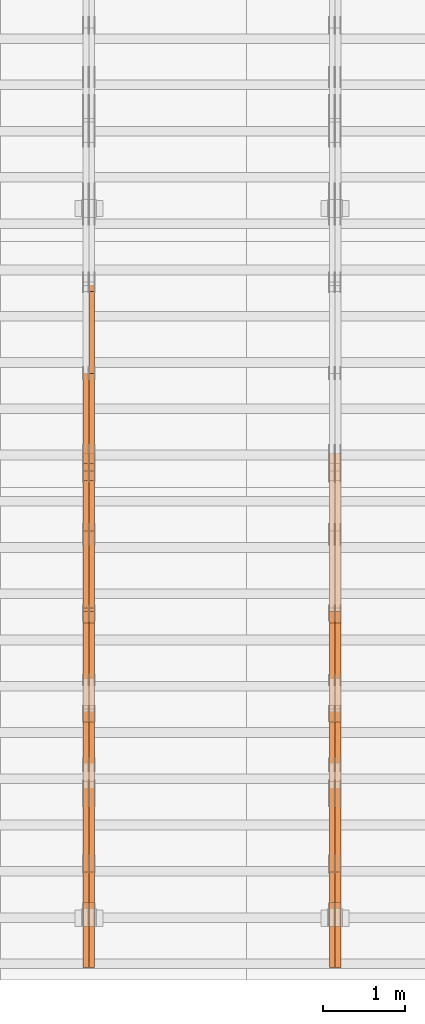
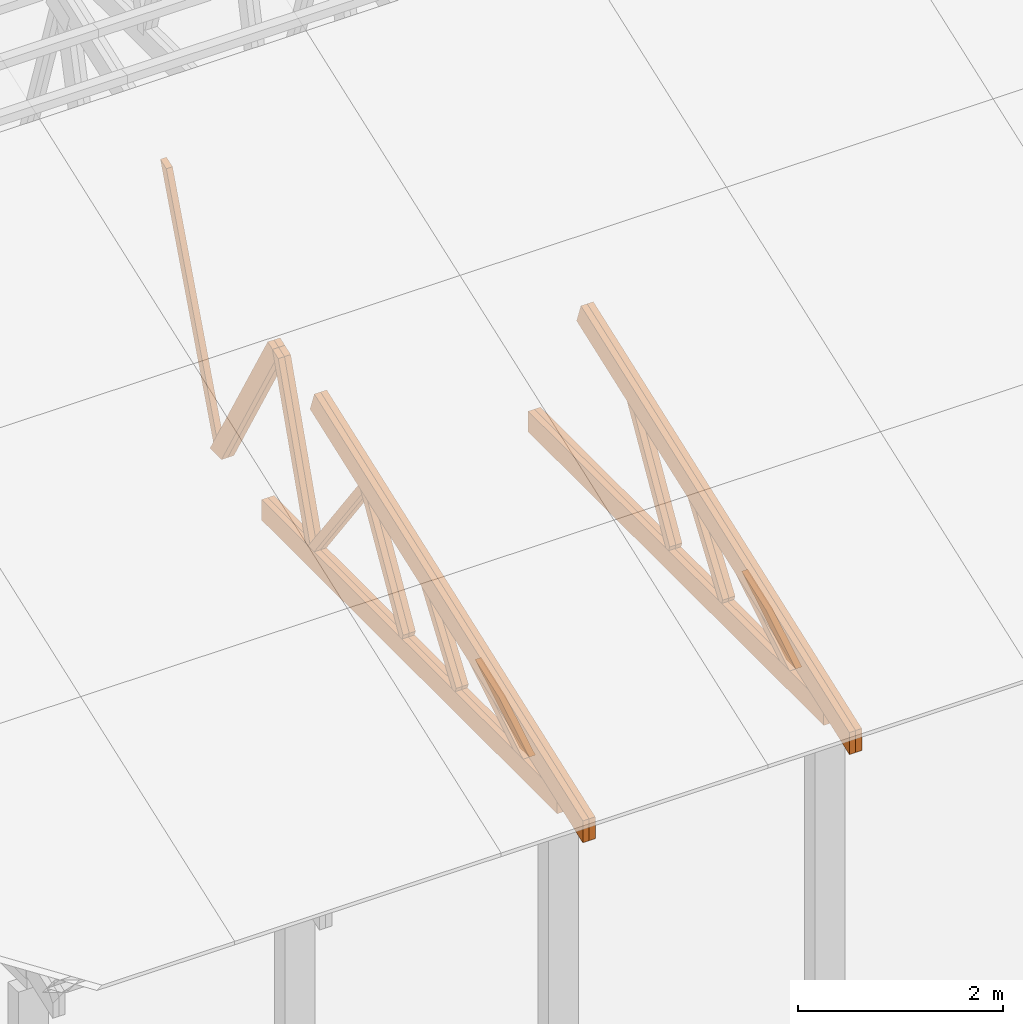
# One storey, part 14 of 189: 27 proxies.
"""IFC2X3 building model written with IfcOpenShell, lengths in millimetres."""

from ifc_helpers import new_model, entity, si_unit, converted_unit, derived_unit, direction, frame, origin, place, context, subcontext, project, spatial, polyline, outline, extrude, source, transform, mapped, material, type_object, type_shapes, element, save


model = new_model("IFC2X3")

# Units and contexts
model_context = context("Model", 3, precision=0.01, world=origin(), true_north=direction((6.12303176911189e-17, 1.0)))
body_context = subcontext(model_context, "Body", "Model", "MODEL_VIEW")
ifc_project = project(units=[si_unit("LENGTHUNIT", "METRE", prefix="MILLI"), si_unit("AREAUNIT", "SQUARE_METRE"), si_unit("VOLUMEUNIT", "CUBIC_METRE"), converted_unit("PLANEANGLEUNIT", "DEGREE", entity("IfcRatioMeasure", 0.0174532925199433), si_unit("PLANEANGLEUNIT", "RADIAN"), dimensions=[0, 0, 0, 0, 0, 0, 0]), si_unit("MASSUNIT", "GRAM", prefix="KILO"), derived_unit("MASSDENSITYUNIT", [(si_unit("MASSUNIT", "GRAM", prefix="KILO"), 1), (si_unit("LENGTHUNIT", "METRE"), -3)]), si_unit("TIMEUNIT", "SECOND"), si_unit("FREQUENCYUNIT", "HERTZ"), si_unit("THERMODYNAMICTEMPERATUREUNIT", "DEGREE_CELSIUS"), derived_unit("THERMALTRANSMITTANCEUNIT", [(si_unit("MASSUNIT", "GRAM", prefix="KILO"), 1), (si_unit("THERMODYNAMICTEMPERATUREUNIT", "KELVIN"), -1), (si_unit("TIMEUNIT", "SECOND"), -3)]), derived_unit("VOLUMETRICFLOWRATEUNIT", [(si_unit("LENGTHUNIT", "METRE"), 3), (si_unit("TIMEUNIT", "SECOND"), -1)]), si_unit("ELECTRICCURRENTUNIT", "AMPERE"), si_unit("ELECTRICVOLTAGEUNIT", "VOLT"), si_unit("POWERUNIT", "WATT"), si_unit("FORCEUNIT", "NEWTON"), si_unit("ILLUMINANCEUNIT", "LUX"), si_unit("LUMINOUSFLUXUNIT", "LUMEN"), si_unit("LUMINOUSINTENSITYUNIT", "CANDELA"), derived_unit("USERDEFINED", [(si_unit("MASSUNIT", "GRAM", prefix="KILO"), -1), (si_unit("LENGTHUNIT", "METRE"), -2), (si_unit("TIMEUNIT", "SECOND"), 3), (si_unit("LUMINOUSFLUXUNIT", "LUMEN"), 1)]), derived_unit("LINEARVELOCITYUNIT", [(si_unit("LENGTHUNIT", "METRE"), 1), (si_unit("TIMEUNIT", "SECOND"), -1)]), si_unit("PRESSUREUNIT", "PASCAL"), derived_unit("USERDEFINED", [(si_unit("LENGTHUNIT", "METRE"), -2), (si_unit("MASSUNIT", "GRAM", prefix="KILO"), 1), (si_unit("TIMEUNIT", "SECOND"), -2)])], contexts=[model_context])

# Site, building, storey
site_placement = place(None, origin())
site = spatial("IfcSite", under=ifc_project, at=site_placement, CompositionType="ELEMENT")
building_placement = place(site_placement, origin())
building = spatial("IfcBuilding", under=site, at=building_placement, CompositionType="ELEMENT")
storey_placement = place(building_placement, origin())
storey = spatial("IfcBuildingStorey", under=building, at=storey_placement, Name="Default", CompositionType="ELEMENT", Elevation=0.0)

# Proxies
ifc_material_1 = material(Name="IfcSurfaceStyle #65994")
building_element_proxy_type_1 = type_object("IfcBuildingElementProxyType", Name="T1-W11 65992", PredefinedType="NOTDEFINED", material=ifc_material_1)
shared_shape_1 = source(origin(), body_context, "Body", "SweptSolid", [
    extrude(outline(polyline([(593.358012843793, -552.565239103314), (742.388662259985, -552.565239103314), (-410.498749190676, 401.275038694583), (-462.246133468927, 382.44069706518), (-463.001792444175, 321.414742446865), (593.358012843793, -552.565239103314)])), frame((599.94412413079, 47.5003788877286, 0.0), z_axis=(0.0, 0.0, 1.0), x_axis=(0.770483455324544, 0.637459994879013, 0.0)), (0.0, 0.0, 1.0), 69.9999999999999),
])
type_shapes(building_element_proxy_type_1, [shared_shape_1])
proxy_1_placement = place(building_placement, frame((12300.0, 2983.26655629375, 269.034992751429), z_axis=(-1.0, 0.0, 0.0), x_axis=(0.0, 0.505995901100606, 0.862535882192379)))
element("IfcBuildingElementProxy", 1, at=proxy_1_placement, inside=storey, type_object=building_element_proxy_type_1, material=ifc_material_1, Name="T1-W11", context=body_context, shape_type="MappedRepresentation", body=[
    mapped(shared_shape_1, transform((0.0, 0.0, 0.0), scale=1.0)),
])
ifc_material_2 = material(Name="IfcSurfaceStyle #65928")
building_element_proxy_type_2 = type_object("IfcBuildingElementProxyType", Name="T1-W11 65926", PredefinedType="NOTDEFINED", material=ifc_material_2)
shared_shape_2 = source(origin(), body_context, "Body", "SweptSolid", [
    extrude(outline(polyline([(593.358012843793, -552.565239103314), (742.388662259985, -552.565239103314), (-410.498749190676, 401.275038694583), (-462.246133468927, 382.44069706518), (-463.001792444175, 321.414742446865), (593.358012843793, -552.565239103314)])), frame((599.94412413079, 47.5003788877286, 0.0), z_axis=(0.0, 0.0, 1.0), x_axis=(0.770483455324544, 0.637459994879013, 0.0)), (0.0, 0.0, 1.0), 69.9999999999999),
])
type_shapes(building_element_proxy_type_2, [shared_shape_2])
proxy_2_placement = place(building_placement, frame((12230.0, 2983.26655629375, 269.034992751429), z_axis=(-1.0, 0.0, 0.0), x_axis=(0.0, 0.505995901100606, 0.862535882192379)))
element("IfcBuildingElementProxy", 2, at=proxy_2_placement, inside=storey, type_object=building_element_proxy_type_2, material=ifc_material_2, Name="T1-W11", context=body_context, shape_type="MappedRepresentation", body=[
    mapped(shared_shape_2, transform((0.0, 0.0, 0.0), scale=1.0)),
])
ifc_material_3 = material(Name="IfcSurfaceStyle #65466")
building_element_proxy_type_3 = type_object("IfcBuildingElementProxyType", Name="T1-W13 65464", PredefinedType="NOTDEFINED", material=ifc_material_3)
shared_shape_3 = source(origin(), body_context, "Body", "SweptSolid", [
    extrude(outline(polyline([(404.740440720218, -341.48092914206), (570.336320797765, -341.48092914206), (-287.911826743206, 259.650691447848), (-342.395697357435, 239.820346030744), (-344.769237417342, 183.490820805529), (404.740440720218, -341.48092914206)])), frame((418.029573061951, 47.5005675782689, 0.0), z_axis=(0.0, 0.0, 1.0), x_axis=(0.819070847746389, 0.573692379565924, 0.0)), (0.0, 0.0, 1.0), 69.9999999999999),
])
type_shapes(building_element_proxy_type_3, [shared_shape_3])
proxy_3_placement = place(building_placement, frame((12300.0, 1951.16403402681, 272.239720286334), z_axis=(-1.0, 0.0, 0.0), x_axis=(0.0, 0.573462629043499, 0.819231721242848)))
element("IfcBuildingElementProxy", 3, at=proxy_3_placement, inside=storey, type_object=building_element_proxy_type_3, material=ifc_material_3, Name="T1-W13", context=body_context, shape_type="MappedRepresentation", body=[
    mapped(shared_shape_3, transform((0.0, 0.0, 0.0), scale=1.0)),
])
ifc_material_4 = material(Name="IfcSurfaceStyle #65400")
building_element_proxy_type_4 = type_object("IfcBuildingElementProxyType", Name="T1-W13 65398", PredefinedType="NOTDEFINED", material=ifc_material_4)
shared_shape_4 = source(origin(), body_context, "Body", "SweptSolid", [
    extrude(outline(polyline([(404.740440720218, -341.48092914206), (570.336320797765, -341.48092914206), (-287.911826743206, 259.650691447848), (-342.395697357435, 239.820346030744), (-344.769237417342, 183.490820805529), (404.740440720218, -341.48092914206)])), frame((418.029573061951, 47.5005675782689, 0.0), z_axis=(0.0, 0.0, 1.0), x_axis=(0.819070847746389, 0.573692379565924, 0.0)), (0.0, 0.0, 1.0), 69.9999999999999),
])
type_shapes(building_element_proxy_type_4, [shared_shape_4])
proxy_4_placement = place(building_placement, frame((12230.0, 1951.16403402681, 272.239720286334), z_axis=(-1.0, 0.0, 0.0), x_axis=(0.0, 0.573462629043499, 0.819231721242848)))
element("IfcBuildingElementProxy", 4, at=proxy_4_placement, inside=storey, type_object=building_element_proxy_type_4, material=ifc_material_4, Name="T1-W13", context=body_context, shape_type="MappedRepresentation", body=[
    mapped(shared_shape_4, transform((0.0, 0.0, 0.0), scale=1.0)),
])
ifc_material_5 = material(Name="IfcSurfaceStyle #64938")
building_element_proxy_type_5 = type_object("IfcBuildingElementProxyType", Name="T1-W12 64936", PredefinedType="NOTDEFINED", material=ifc_material_5)
shared_shape_5 = source(origin(), body_context, "Body", "SweptSolid", [
    extrude(outline(polyline([(-671.888430889784, -47.499785620702), (344.892972119224, -47.499785620702), (503.856463083211, 47.4997856207019), (-176.861004312651, 47.499785620702), (-671.888430889784, -47.499785620702)])), frame((503.857114243549, 47.5002636410509, 0.0), z_axis=(0.0, 0.0, 1.0), x_axis=(-1.0, 0.0, 0.0)), (0.0, 0.0, 1.0), 69.9999999999999),
])
type_shapes(building_element_proxy_type_5, [shared_shape_5])
proxy_5_placement = place(building_placement, frame((12300.0, 665.58122707747, 245.000076287477), z_axis=(-1.0, 0.0, 0.0), x_axis=(0.0, 0.858392121304013, 0.51299411895576)))
element("IfcBuildingElementProxy", 5, at=proxy_5_placement, inside=storey, type_object=building_element_proxy_type_5, material=ifc_material_5, Name="T1-W12", context=body_context, shape_type="MappedRepresentation", body=[
    mapped(shared_shape_5, transform((0.0, 0.0, 0.0), scale=1.0)),
])
ifc_material_6 = material(Name="IfcSurfaceStyle #64881")
building_element_proxy_type_6 = type_object("IfcBuildingElementProxyType", Name="T1-W12 64879", PredefinedType="NOTDEFINED", material=ifc_material_6)
shared_shape_6 = source(origin(), body_context, "Body", "SweptSolid", [
    extrude(outline(polyline([(-671.888430889784, -47.499785620702), (344.892972119224, -47.499785620702), (503.856463083211, 47.4997856207019), (-176.861004312651, 47.499785620702), (-671.888430889784, -47.499785620702)])), frame((503.857114243549, 47.5002636410509, 0.0), z_axis=(0.0, 0.0, 1.0), x_axis=(-1.0, 0.0, 0.0)), (0.0, 0.0, 1.0), 69.9999999999999),
])
type_shapes(building_element_proxy_type_6, [shared_shape_6])
proxy_6_placement = place(building_placement, frame((12230.0, 665.58122707747, 245.000076287477), z_axis=(-1.0, 0.0, 0.0), x_axis=(0.0, 0.858392121304013, 0.51299411895576)))
element("IfcBuildingElementProxy", 6, at=proxy_6_placement, inside=storey, type_object=building_element_proxy_type_6, material=ifc_material_6, Name="T1-W12", context=body_context, shape_type="MappedRepresentation", body=[
    mapped(shared_shape_6, transform((0.0, 0.0, 0.0), scale=1.0)),
])
ifc_material_7 = material(Name="IfcSurfaceStyle #64122")
building_element_proxy_type_7 = type_object("IfcBuildingElementProxyType", Name="T1-B2 64120", PredefinedType="NOTDEFINED", material=ifc_material_7)
shared_shape_7 = source(origin(), body_context, "Body", "SweptSolid", [
    extrude(outline(polyline([(-3399.385546875, -125.855288696291), (2363.08125, -125.855288696291), (2363.08125, 13.4211547851572), (2072.60859375, 119.144711303712), (-3399.385546875, 119.144711303712), (-3399.385546875, -125.855288696291)])), frame((2363.08125, 119.144711303712, 0.0), z_axis=(0.0, 0.0, 1.0), x_axis=(-1.0, 0.0, 0.0)), (0.0, 0.0, 1.0), 69.9999999999997),
])
type_shapes(building_element_proxy_type_7, [shared_shape_7])
proxy_7_placement = place(building_placement, frame((12300.0, 0.0, 245.0), z_axis=(-1.0, 0.0, 0.0), x_axis=(0.0, 1.0, 0.0)))
element("IfcBuildingElementProxy", 7, at=proxy_7_placement, inside=storey, type_object=building_element_proxy_type_7, material=ifc_material_7, Name="T1-B2", context=body_context, shape_type="MappedRepresentation", body=[
    mapped(shared_shape_7, transform((0.0, 0.0, 0.0), scale=1.0)),
])
ifc_material_8 = material(Name="IfcSurfaceStyle #64056")
building_element_proxy_type_8 = type_object("IfcBuildingElementProxyType", Name="T1-B2 64054", PredefinedType="NOTDEFINED", material=ifc_material_8)
shared_shape_8 = source(origin(), body_context, "Body", "SweptSolid", [
    extrude(outline(polyline([(-3399.385546875, -125.855288696291), (2363.08125, -125.855288696291), (2363.08125, 13.4211547851572), (2072.60859375, 119.144711303712), (-3399.385546875, 119.144711303712), (-3399.385546875, -125.855288696291)])), frame((2363.08125, 119.144711303712, 0.0), z_axis=(0.0, 0.0, 1.0), x_axis=(-1.0, 0.0, 0.0)), (0.0, 0.0, 1.0), 69.9999999999997),
])
type_shapes(building_element_proxy_type_8, [shared_shape_8])
proxy_8_placement = place(building_placement, frame((12230.0, 0.0, 245.0), z_axis=(-1.0, 0.0, 0.0), x_axis=(0.0, 1.0, 0.0)))
element("IfcBuildingElementProxy", 8, at=proxy_8_placement, inside=storey, type_object=building_element_proxy_type_8, material=ifc_material_8, Name="T1-B2", context=body_context, shape_type="MappedRepresentation", body=[
    mapped(shared_shape_8, transform((0.0, 0.0, 0.0), scale=1.0)),
])
ifc_material_9 = material(Name="IfcSurfaceStyle #63990")
building_element_proxy_type_9 = type_object("IfcBuildingElementProxyType", Name="T1-T2 63988", PredefinedType="NOTDEFINED", material=ifc_material_9)
shared_shape_9 = source(origin(), body_context, "Body", "SweptSolid", [
    extrude(outline(polyline([(-2763.12044548193, -122.499971764318), (2807.70681121203, -122.499971764318), (2807.70678531127, 122.499971764318), (-2852.29315104137, 122.499971764318), (-2763.12044548193, -122.499971764318)])), frame((2807.70684902043, 122.500023191939, 0.0), z_axis=(0.0, 0.0, 1.0), x_axis=(-1.0, 0.0, 0.0)), (0.0, 0.0, 1.0), 69.9999999999997),
])
type_shapes(building_element_proxy_type_9, [shared_shape_9])
proxy_9_placement = place(building_placement, frame((12300.0, 4818.66023370631, 1893.1253396746), z_axis=(-1.0, 0.0, 0.0), x_axis=(0.0, -0.939692620785908, -0.342020143325669)))
element("IfcBuildingElementProxy", 9, at=proxy_9_placement, inside=storey, type_object=building_element_proxy_type_9, material=ifc_material_9, Name="T1-T2", context=body_context, shape_type="MappedRepresentation", body=[
    mapped(shared_shape_9, transform((0.0, 0.0, 0.0), scale=1.0)),
])
ifc_material_10 = material(Name="IfcSurfaceStyle #63933")
building_element_proxy_type_10 = type_object("IfcBuildingElementProxyType", Name="T1-T2 63931", PredefinedType="NOTDEFINED", material=ifc_material_10)
shared_shape_10 = source(origin(), body_context, "Body", "SweptSolid", [
    extrude(outline(polyline([(-2763.12044548193, -122.499971764318), (2807.70681121203, -122.499971764318), (2807.70678531127, 122.499971764318), (-2852.29315104137, 122.499971764318), (-2763.12044548193, -122.499971764318)])), frame((2807.70684902043, 122.500023191939, 0.0), z_axis=(0.0, 0.0, 1.0), x_axis=(-1.0, 0.0, 0.0)), (0.0, 0.0, 1.0), 69.9999999999997),
])
type_shapes(building_element_proxy_type_10, [shared_shape_10])
proxy_10_placement = place(building_placement, frame((12230.0, 4818.66023370631, 1893.1253396746), z_axis=(-1.0, 0.0, 0.0), x_axis=(0.0, -0.939692620785908, -0.342020143325669)))
element("IfcBuildingElementProxy", 10, at=proxy_10_placement, inside=storey, type_object=building_element_proxy_type_10, material=ifc_material_10, Name="T1-T2", context=body_context, shape_type="MappedRepresentation", body=[
    mapped(shared_shape_10, transform((0.0, 0.0, 0.0), scale=1.0)),
])
ifc_material_11 = material(Name="IfcSurfaceStyle #51260")
building_element_proxy_type_11 = type_object("IfcBuildingElementProxyType", Name="T1-W8 51258", PredefinedType="NOTDEFINED", material=ifc_material_11)
shared_shape_11 = source(origin(), body_context, "Body", "SweptSolid", [
    extrude(outline(polyline([(-1781.70529904483, -47.500320228718), (1161.65050357787, -47.5003202287179), (1179.56135870849, 0.000731866266039397), (1140.6022069428, 47.4998218997103), (-1700.10877018433, 47.5000866914596), (-1781.70529904483, -47.500320228718)])), frame((1179.56135870869, 47.5007236522113, 0.0), z_axis=(0.0, 0.0, 1.0), x_axis=(-1.0, 3.74658825645258e-07, 0.0)), (0.0, 0.0, 1.0), 69.9999999999998),
])
type_shapes(building_element_proxy_type_11, [shared_shape_11])
proxy_11_placement = place(building_placement, frame((9300.0, 6723.5697965901, 261.758864533503), z_axis=(-1.0, 0.0, 0.0), x_axis=(0.0, 0.352814979177603, 0.93569310698963)))
element("IfcBuildingElementProxy", 11, at=proxy_11_placement, inside=storey, type_object=building_element_proxy_type_11, material=ifc_material_11, Name="T1-W8", context=body_context, shape_type="MappedRepresentation", body=[
    mapped(shared_shape_11, transform((0.0, 0.0, 0.0), scale=1.0)),
])
ifc_material_12 = material(Name="IfcSurfaceStyle #50996")
building_element_proxy_type_12 = type_object("IfcBuildingElementProxyType", Name="T1-W2 50994", PredefinedType="NOTDEFINED", material=ifc_material_12)
shared_shape_12 = source(origin(), body_context, "Body", "SweptSolid", [
    extrude(outline(polyline([(-765.033104991319, -1130.91940266317), (-539.905732758898, -1130.91940266317), (493.678280567457, 660.584515081422), (452.144945212405, 783.697385511457), (359.115611970356, 817.556904733455), (-765.033104991319, -1130.91940266317)])), frame((904.774360566371, 97.5002668805543, 0.0), z_axis=(0.0, 0.0, 1.0), x_axis=(-0.499731715721184, 0.866180242387438, 0.0)), (0.0, 0.0, 1.0), 69.9999999999998),
])
type_shapes(building_element_proxy_type_12, [shared_shape_12])
proxy_12_placement = place(building_placement, frame((9300.0, 5635.28919163287, 2208.3400784451), z_axis=(-1.0, 0.0, 0.0), x_axis=(0.0, 0.5, -0.866025403784439)))
element("IfcBuildingElementProxy", 12, at=proxy_12_placement, inside=storey, type_object=building_element_proxy_type_12, material=ifc_material_12, Name="T1-W2", context=body_context, shape_type="MappedRepresentation", body=[
    mapped(shared_shape_12, transform((0.0, 0.0, 0.0), scale=1.0)),
])
ifc_material_13 = material(Name="IfcSurfaceStyle #50930")
building_element_proxy_type_13 = type_object("IfcBuildingElementProxyType", Name="T1-W2 50928", PredefinedType="NOTDEFINED", material=ifc_material_13)
shared_shape_13 = source(origin(), body_context, "Body", "SweptSolid", [
    extrude(outline(polyline([(-765.033104991319, -1130.91940266317), (-539.905732758898, -1130.91940266317), (493.678280567457, 660.584515081422), (452.144945212405, 783.697385511457), (359.115611970356, 817.556904733455), (-765.033104991319, -1130.91940266317)])), frame((904.774360566371, 97.5002668805543, 0.0), z_axis=(0.0, 0.0, 1.0), x_axis=(-0.499731715721184, 0.866180242387438, 0.0)), (0.0, 0.0, 1.0), 69.9999999999998),
])
type_shapes(building_element_proxy_type_13, [shared_shape_13])
proxy_13_placement = place(building_placement, frame((9230.0, 5635.28919163287, 2208.3400784451), z_axis=(-1.0, 0.0, 0.0), x_axis=(0.0, 0.5, -0.866025403784439)))
element("IfcBuildingElementProxy", 13, at=proxy_13_placement, inside=storey, type_object=building_element_proxy_type_13, material=ifc_material_13, Name="T1-W2", context=body_context, shape_type="MappedRepresentation", body=[
    mapped(shared_shape_13, transform((0.0, 0.0, 0.0), scale=1.0)),
])
ifc_material_14 = material(Name="IfcSurfaceStyle #50732")
building_element_proxy_type_14 = type_object("IfcBuildingElementProxyType", Name="T1-W9 50730", PredefinedType="NOTDEFINED", material=ifc_material_14)
shared_shape_14 = source(origin(), body_context, "Body", "SweptSolid", [
    extrude(outline(polyline([(-1227.3969292634, -47.5000382896404), (793.242467803064, -47.5000382896404), (809.267705296822, 1.0956605530188e-05), (776.329919980315, 47.5000328113376), (-1151.4431638168, 47.5000328113376), (-1227.3969292634, -47.5000382896404)])), frame((809.267705296822, 47.5000328113376, 0.0), z_axis=(0.0, 0.0, 1.0), x_axis=(-1.0, 0.0, 0.0)), (0.0, 0.0, 1.0), 69.9999999999999),
])
type_shapes(building_element_proxy_type_14, [shared_shape_14])
proxy_14_placement = place(building_placement, frame((9300.0, 4809.76380889125, 260.184242613649), z_axis=(-1.0, 0.0, 0.0), x_axis=(0.0, 0.31966811847134, 0.947529574226047)))
element("IfcBuildingElementProxy", 14, at=proxy_14_placement, inside=storey, type_object=building_element_proxy_type_14, material=ifc_material_14, Name="T1-W9", context=body_context, shape_type="MappedRepresentation", body=[
    mapped(shared_shape_14, transform((0.0, 0.0, 0.0), scale=1.0)),
])
ifc_material_15 = material(Name="IfcSurfaceStyle #50666")
building_element_proxy_type_15 = type_object("IfcBuildingElementProxyType", Name="T1-W9 50664", PredefinedType="NOTDEFINED", material=ifc_material_15)
shared_shape_15 = source(origin(), body_context, "Body", "SweptSolid", [
    extrude(outline(polyline([(-1227.3969292634, -47.5000382896404), (793.242467803064, -47.5000382896404), (809.267705296822, 1.0956605530188e-05), (776.329919980315, 47.5000328113376), (-1151.4431638168, 47.5000328113376), (-1227.3969292634, -47.5000382896404)])), frame((809.267705296822, 47.5000328113376, 0.0), z_axis=(0.0, 0.0, 1.0), x_axis=(-1.0, 0.0, 0.0)), (0.0, 0.0, 1.0), 69.9999999999999),
])
type_shapes(building_element_proxy_type_15, [shared_shape_15])
proxy_15_placement = place(building_placement, frame((9230.0, 4809.76380889125, 260.184242613649), z_axis=(-1.0, 0.0, 0.0), x_axis=(0.0, 0.31966811847134, 0.947529574226047)))
element("IfcBuildingElementProxy", 15, at=proxy_15_placement, inside=storey, type_object=building_element_proxy_type_15, material=ifc_material_15, Name="T1-W9", context=body_context, shape_type="MappedRepresentation", body=[
    mapped(shared_shape_15, transform((0.0, 0.0, 0.0), scale=1.0)),
])
ifc_material_16 = material(Name="IfcSurfaceStyle #50468")
building_element_proxy_type_16 = type_object("IfcBuildingElementProxyType", Name="T1-W10 50466", PredefinedType="NOTDEFINED", material=ifc_material_16)
shared_shape_16 = source(origin(), body_context, "Body", "SweptSolid", [
    extrude(outline(polyline([(-922.639472665691, -47.5001890573134), (629.920966338637, -47.5001890573134), (650.067737483374, 0.000694680531158376), (635.89112756682, 47.4998417170478), (-993.240358723139, 47.4998417170478), (-922.639472665691, -47.5001890573134)])), frame((650.068202545693, 47.4999816623145, 0.0), z_axis=(0.0, 0.0, 1.0), x_axis=(-1.0, 0.0, 0.0)), (0.0, 0.0, 1.0), 69.9999999999999),
])
type_shapes(building_element_proxy_type_16, [shared_shape_16])
proxy_16_placement = place(building_placement, frame((9300.0, 3874.56126239818, 1563.95828147518), z_axis=(-1.0, 0.0, 0.0), x_axis=(0.0, 0.596486092002, -0.802623412347398)))
element("IfcBuildingElementProxy", 16, at=proxy_16_placement, inside=storey, type_object=building_element_proxy_type_16, material=ifc_material_16, Name="T1-W10", context=body_context, shape_type="MappedRepresentation", body=[
    mapped(shared_shape_16, transform((0.0, 0.0, 0.0), scale=1.0)),
])
ifc_material_17 = material(Name="IfcSurfaceStyle #50402")
building_element_proxy_type_17 = type_object("IfcBuildingElementProxyType", Name="T1-W10 50400", PredefinedType="NOTDEFINED", material=ifc_material_17)
shared_shape_17 = source(origin(), body_context, "Body", "SweptSolid", [
    extrude(outline(polyline([(-922.639472665691, -47.5001890573134), (629.920966338637, -47.5001890573134), (650.067737483374, 0.000694680531158376), (635.89112756682, 47.4998417170478), (-993.240358723139, 47.4998417170478), (-922.639472665691, -47.5001890573134)])), frame((650.068202545693, 47.4999816623145, 0.0), z_axis=(0.0, 0.0, 1.0), x_axis=(-1.0, 0.0, 0.0)), (0.0, 0.0, 1.0), 69.9999999999999),
])
type_shapes(building_element_proxy_type_17, [shared_shape_17])
proxy_17_placement = place(building_placement, frame((9230.0, 3874.56126239818, 1563.95828147518), z_axis=(-1.0, 0.0, 0.0), x_axis=(0.0, 0.596486092002, -0.802623412347398)))
element("IfcBuildingElementProxy", 17, at=proxy_17_placement, inside=storey, type_object=building_element_proxy_type_17, material=ifc_material_17, Name="T1-W10", context=body_context, shape_type="MappedRepresentation", body=[
    mapped(shared_shape_17, transform((0.0, 0.0, 0.0), scale=1.0)),
])
ifc_material_18 = material(Name="IfcSurfaceStyle #50204")
building_element_proxy_type_18 = type_object("IfcBuildingElementProxyType", Name="T1-W11 50202", PredefinedType="NOTDEFINED", material=ifc_material_18)
shared_shape_18 = source(origin(), body_context, "Body", "SweptSolid", [
    extrude(outline(polyline([(593.358012843793, -552.565239103314), (742.388662259985, -552.565239103314), (-410.498749190676, 401.275038694583), (-462.246133468927, 382.44069706518), (-463.001792444175, 321.414742446865), (593.358012843793, -552.565239103314)])), frame((599.94412413079, 47.5003788877286, 0.0), z_axis=(0.0, 0.0, 1.0), x_axis=(0.770483455324544, 0.637459994879013, 0.0)), (0.0, 0.0, 1.0), 69.9999999999999),
])
type_shapes(building_element_proxy_type_18, [shared_shape_18])
proxy_18_placement = place(building_placement, frame((9300.0, 2983.26655629375, 269.034992751429), z_axis=(-1.0, 0.0, 0.0), x_axis=(0.0, 0.505995901100606, 0.862535882192379)))
element("IfcBuildingElementProxy", 18, at=proxy_18_placement, inside=storey, type_object=building_element_proxy_type_18, material=ifc_material_18, Name="T1-W11", context=body_context, shape_type="MappedRepresentation", body=[
    mapped(shared_shape_18, transform((0.0, 0.0, 0.0), scale=1.0)),
])
ifc_material_19 = material(Name="IfcSurfaceStyle #50138")
building_element_proxy_type_19 = type_object("IfcBuildingElementProxyType", Name="T1-W11 50136", PredefinedType="NOTDEFINED", material=ifc_material_19)
shared_shape_19 = source(origin(), body_context, "Body", "SweptSolid", [
    extrude(outline(polyline([(593.358012843793, -552.565239103314), (742.388662259985, -552.565239103314), (-410.498749190676, 401.275038694583), (-462.246133468927, 382.44069706518), (-463.001792444175, 321.414742446865), (593.358012843793, -552.565239103314)])), frame((599.94412413079, 47.5003788877286, 0.0), z_axis=(0.0, 0.0, 1.0), x_axis=(0.770483455324544, 0.637459994879013, 0.0)), (0.0, 0.0, 1.0), 69.9999999999999),
])
type_shapes(building_element_proxy_type_19, [shared_shape_19])
proxy_19_placement = place(building_placement, frame((9230.0, 2983.26655629375, 269.034992751429), z_axis=(-1.0, 0.0, 0.0), x_axis=(0.0, 0.505995901100606, 0.862535882192379)))
element("IfcBuildingElementProxy", 19, at=proxy_19_placement, inside=storey, type_object=building_element_proxy_type_19, material=ifc_material_19, Name="T1-W11", context=body_context, shape_type="MappedRepresentation", body=[
    mapped(shared_shape_19, transform((0.0, 0.0, 0.0), scale=1.0)),
])
ifc_material_20 = material(Name="IfcSurfaceStyle #49676")
building_element_proxy_type_20 = type_object("IfcBuildingElementProxyType", Name="T1-W13 49674", PredefinedType="NOTDEFINED", material=ifc_material_20)
shared_shape_20 = source(origin(), body_context, "Body", "SweptSolid", [
    extrude(outline(polyline([(404.740440720218, -341.48092914206), (570.336320797765, -341.48092914206), (-287.911826743206, 259.650691447848), (-342.395697357435, 239.820346030744), (-344.769237417342, 183.490820805529), (404.740440720218, -341.48092914206)])), frame((418.029573061951, 47.5005675782689, 0.0), z_axis=(0.0, 0.0, 1.0), x_axis=(0.819070847746389, 0.573692379565924, 0.0)), (0.0, 0.0, 1.0), 69.9999999999999),
])
type_shapes(building_element_proxy_type_20, [shared_shape_20])
proxy_20_placement = place(building_placement, frame((9300.0, 1951.16403402681, 272.239720286334), z_axis=(-1.0, 0.0, 0.0), x_axis=(0.0, 0.573462629043499, 0.819231721242848)))
element("IfcBuildingElementProxy", 20, at=proxy_20_placement, inside=storey, type_object=building_element_proxy_type_20, material=ifc_material_20, Name="T1-W13", context=body_context, shape_type="MappedRepresentation", body=[
    mapped(shared_shape_20, transform((0.0, 0.0, 0.0), scale=1.0)),
])
ifc_material_21 = material(Name="IfcSurfaceStyle #49610")
building_element_proxy_type_21 = type_object("IfcBuildingElementProxyType", Name="T1-W13 49608", PredefinedType="NOTDEFINED", material=ifc_material_21)
shared_shape_21 = source(origin(), body_context, "Body", "SweptSolid", [
    extrude(outline(polyline([(404.740440720218, -341.48092914206), (570.336320797765, -341.48092914206), (-287.911826743206, 259.650691447848), (-342.395697357435, 239.820346030744), (-344.769237417342, 183.490820805529), (404.740440720218, -341.48092914206)])), frame((418.029573061951, 47.5005675782689, 0.0), z_axis=(0.0, 0.0, 1.0), x_axis=(0.819070847746389, 0.573692379565924, 0.0)), (0.0, 0.0, 1.0), 69.9999999999999),
])
type_shapes(building_element_proxy_type_21, [shared_shape_21])
proxy_21_placement = place(building_placement, frame((9230.0, 1951.16403402681, 272.239720286334), z_axis=(-1.0, 0.0, 0.0), x_axis=(0.0, 0.573462629043499, 0.819231721242848)))
element("IfcBuildingElementProxy", 21, at=proxy_21_placement, inside=storey, type_object=building_element_proxy_type_21, material=ifc_material_21, Name="T1-W13", context=body_context, shape_type="MappedRepresentation", body=[
    mapped(shared_shape_21, transform((0.0, 0.0, 0.0), scale=1.0)),
])
ifc_material_22 = material(Name="IfcSurfaceStyle #49148")
building_element_proxy_type_22 = type_object("IfcBuildingElementProxyType", Name="T1-W12 49146", PredefinedType="NOTDEFINED", material=ifc_material_22)
shared_shape_22 = source(origin(), body_context, "Body", "SweptSolid", [
    extrude(outline(polyline([(-671.888430889784, -47.499785620702), (344.892972119224, -47.499785620702), (503.856463083211, 47.4997856207019), (-176.861004312651, 47.499785620702), (-671.888430889784, -47.499785620702)])), frame((503.857114243549, 47.5002636410509, 0.0), z_axis=(0.0, 0.0, 1.0), x_axis=(-1.0, 0.0, 0.0)), (0.0, 0.0, 1.0), 69.9999999999999),
])
type_shapes(building_element_proxy_type_22, [shared_shape_22])
proxy_22_placement = place(building_placement, frame((9300.0, 665.58122707747, 245.000076287477), z_axis=(-1.0, 0.0, 0.0), x_axis=(0.0, 0.858392121304013, 0.51299411895576)))
element("IfcBuildingElementProxy", 22, at=proxy_22_placement, inside=storey, type_object=building_element_proxy_type_22, material=ifc_material_22, Name="T1-W12", context=body_context, shape_type="MappedRepresentation", body=[
    mapped(shared_shape_22, transform((0.0, 0.0, 0.0), scale=1.0)),
])
ifc_material_23 = material(Name="IfcSurfaceStyle #49091")
building_element_proxy_type_23 = type_object("IfcBuildingElementProxyType", Name="T1-W12 49089", PredefinedType="NOTDEFINED", material=ifc_material_23)
shared_shape_23 = source(origin(), body_context, "Body", "SweptSolid", [
    extrude(outline(polyline([(-671.888430889784, -47.499785620702), (344.892972119224, -47.499785620702), (503.856463083211, 47.4997856207019), (-176.861004312651, 47.499785620702), (-671.888430889784, -47.499785620702)])), frame((503.857114243549, 47.5002636410509, 0.0), z_axis=(0.0, 0.0, 1.0), x_axis=(-1.0, 0.0, 0.0)), (0.0, 0.0, 1.0), 69.9999999999999),
])
type_shapes(building_element_proxy_type_23, [shared_shape_23])
proxy_23_placement = place(building_placement, frame((9230.0, 665.58122707747, 245.000076287477), z_axis=(-1.0, 0.0, 0.0), x_axis=(0.0, 0.858392121304013, 0.51299411895576)))
element("IfcBuildingElementProxy", 23, at=proxy_23_placement, inside=storey, type_object=building_element_proxy_type_23, material=ifc_material_23, Name="T1-W12", context=body_context, shape_type="MappedRepresentation", body=[
    mapped(shared_shape_23, transform((0.0, 0.0, 0.0), scale=1.0)),
])
ifc_material_24 = material(Name="IfcSurfaceStyle #48332")
building_element_proxy_type_24 = type_object("IfcBuildingElementProxyType", Name="T1-B2 48330", PredefinedType="NOTDEFINED", material=ifc_material_24)
shared_shape_24 = source(origin(), body_context, "Body", "SweptSolid", [
    extrude(outline(polyline([(-3399.385546875, -125.855288696291), (2363.08125, -125.855288696291), (2363.08125, 13.4211547851572), (2072.60859375, 119.144711303712), (-3399.385546875, 119.144711303712), (-3399.385546875, -125.855288696291)])), frame((2363.08125, 119.144711303712, 0.0), z_axis=(0.0, 0.0, 1.0), x_axis=(-1.0, 0.0, 0.0)), (0.0, 0.0, 1.0), 69.9999999999997),
])
type_shapes(building_element_proxy_type_24, [shared_shape_24])
proxy_24_placement = place(building_placement, frame((9300.0, 0.0, 245.0), z_axis=(-1.0, 0.0, 0.0), x_axis=(0.0, 1.0, 0.0)))
element("IfcBuildingElementProxy", 24, at=proxy_24_placement, inside=storey, type_object=building_element_proxy_type_24, material=ifc_material_24, Name="T1-B2", context=body_context, shape_type="MappedRepresentation", body=[
    mapped(shared_shape_24, transform((0.0, 0.0, 0.0), scale=1.0)),
])
ifc_material_25 = material(Name="IfcSurfaceStyle #48266")
building_element_proxy_type_25 = type_object("IfcBuildingElementProxyType", Name="T1-B2 48264", PredefinedType="NOTDEFINED", material=ifc_material_25)
shared_shape_25 = source(origin(), body_context, "Body", "SweptSolid", [
    extrude(outline(polyline([(-3399.385546875, -125.855288696291), (2363.08125, -125.855288696291), (2363.08125, 13.4211547851572), (2072.60859375, 119.144711303712), (-3399.385546875, 119.144711303712), (-3399.385546875, -125.855288696291)])), frame((2363.08125, 119.144711303712, 0.0), z_axis=(0.0, 0.0, 1.0), x_axis=(-1.0, 0.0, 0.0)), (0.0, 0.0, 1.0), 69.9999999999997),
])
type_shapes(building_element_proxy_type_25, [shared_shape_25])
proxy_25_placement = place(building_placement, frame((9230.0, 0.0, 245.0), z_axis=(-1.0, 0.0, 0.0), x_axis=(0.0, 1.0, 0.0)))
element("IfcBuildingElementProxy", 25, at=proxy_25_placement, inside=storey, type_object=building_element_proxy_type_25, material=ifc_material_25, Name="T1-B2", context=body_context, shape_type="MappedRepresentation", body=[
    mapped(shared_shape_25, transform((0.0, 0.0, 0.0), scale=1.0)),
])
ifc_material_26 = material(Name="IfcSurfaceStyle #48200")
building_element_proxy_type_26 = type_object("IfcBuildingElementProxyType", Name="T1-T2 48198", PredefinedType="NOTDEFINED", material=ifc_material_26)
shared_shape_26 = source(origin(), body_context, "Body", "SweptSolid", [
    extrude(outline(polyline([(-2763.12044548193, -122.499971764318), (2807.70681121203, -122.499971764318), (2807.70678531127, 122.499971764318), (-2852.29315104137, 122.499971764318), (-2763.12044548193, -122.499971764318)])), frame((2807.70684902043, 122.500023191939, 0.0), z_axis=(0.0, 0.0, 1.0), x_axis=(-1.0, 0.0, 0.0)), (0.0, 0.0, 1.0), 69.9999999999997),
])
type_shapes(building_element_proxy_type_26, [shared_shape_26])
proxy_26_placement = place(building_placement, frame((9300.0, 4818.66023370631, 1893.1253396746), z_axis=(-1.0, 0.0, 0.0), x_axis=(0.0, -0.939692620785908, -0.342020143325669)))
element("IfcBuildingElementProxy", 26, at=proxy_26_placement, inside=storey, type_object=building_element_proxy_type_26, material=ifc_material_26, Name="T1-T2", context=body_context, shape_type="MappedRepresentation", body=[
    mapped(shared_shape_26, transform((0.0, 0.0, 0.0), scale=1.0)),
])
ifc_material_27 = material(Name="IfcSurfaceStyle #48143")
building_element_proxy_type_27 = type_object("IfcBuildingElementProxyType", Name="T1-T2 48141", PredefinedType="NOTDEFINED", material=ifc_material_27)
shared_shape_27 = source(origin(), body_context, "Body", "SweptSolid", [
    extrude(outline(polyline([(-2763.12044548193, -122.499971764318), (2807.70681121203, -122.499971764318), (2807.70678531127, 122.499971764318), (-2852.29315104137, 122.499971764318), (-2763.12044548193, -122.499971764318)])), frame((2807.70684902043, 122.500023191939, 0.0), z_axis=(0.0, 0.0, 1.0), x_axis=(-1.0, 0.0, 0.0)), (0.0, 0.0, 1.0), 69.9999999999997),
])
type_shapes(building_element_proxy_type_27, [shared_shape_27])
proxy_27_placement = place(building_placement, frame((9230.0, 4818.66023370631, 1893.1253396746), z_axis=(-1.0, 0.0, 0.0), x_axis=(0.0, -0.939692620785908, -0.342020143325669)))
element("IfcBuildingElementProxy", 27, at=proxy_27_placement, inside=storey, type_object=building_element_proxy_type_27, material=ifc_material_27, Name="T1-T2", context=body_context, shape_type="MappedRepresentation", body=[
    mapped(shared_shape_27, transform((0.0, 0.0, 0.0), scale=1.0)),
])

save(model, "model.ifc")
